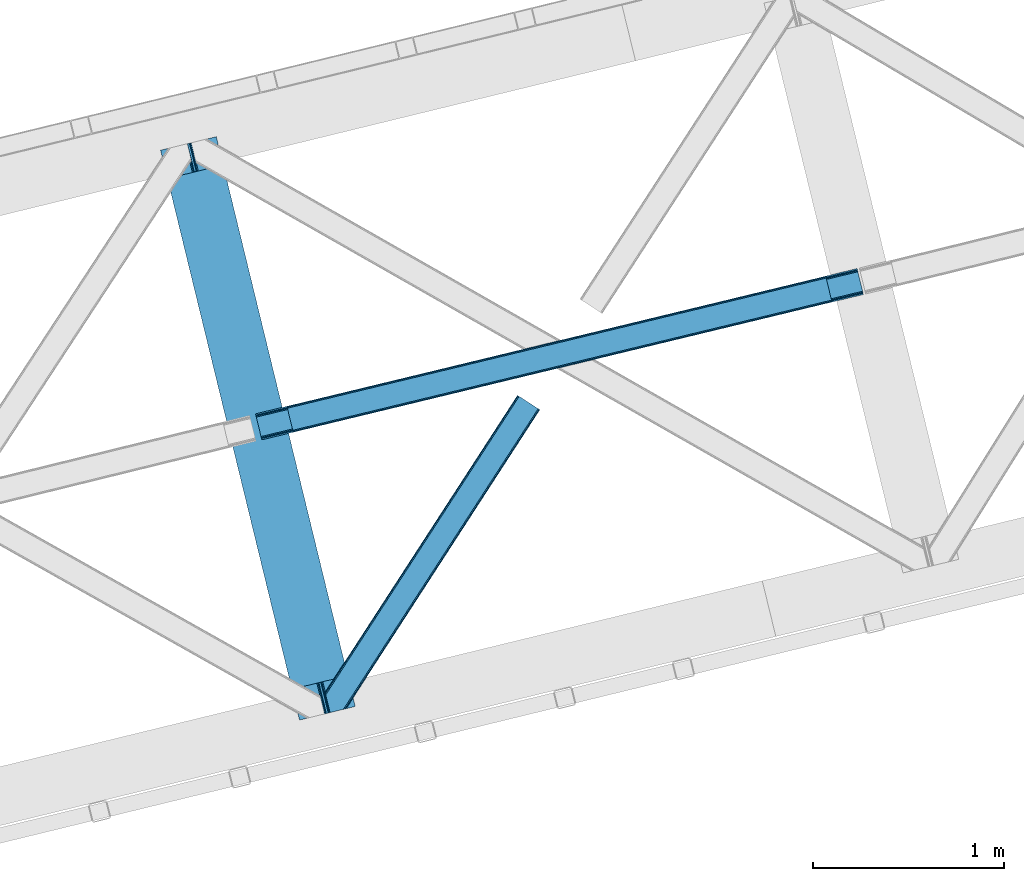
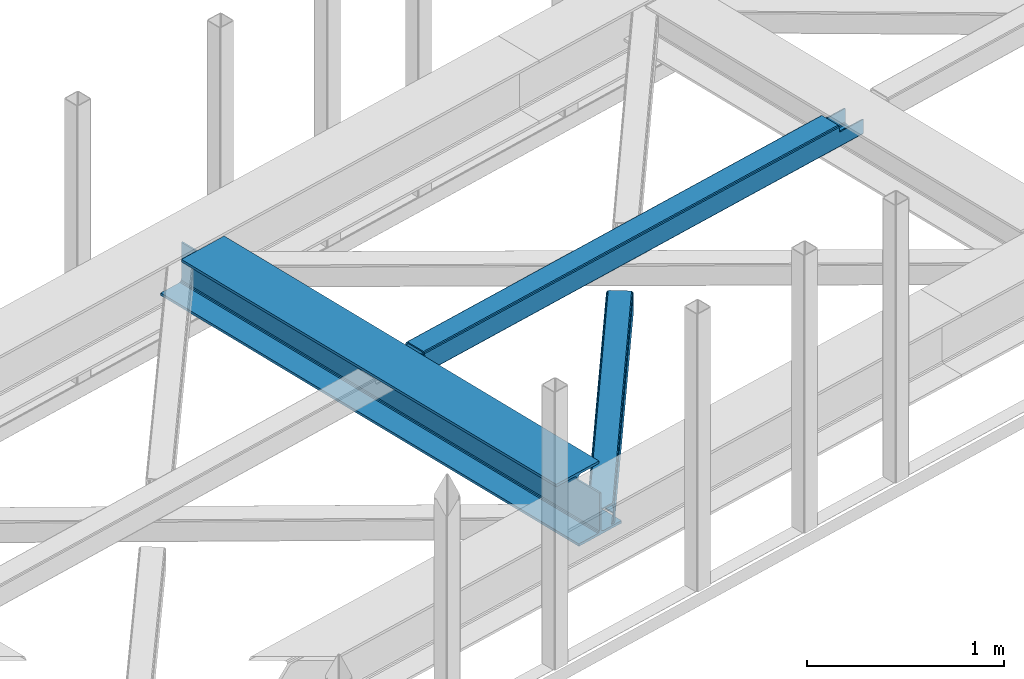
# One storey, part 36 of 66: 2 beams, 1 member.
"""IFC4 building model written with IfcOpenShell, lengths in millimetres."""

from ifc_helpers import new_model, entity, si_unit, converted_unit, derived_unit, direction, frame, origin, place, context, subcontext, project, spatial, triangles, polygons, material, type_object, element, save


model = new_model("IFC4")

# Units and contexts
model_context = context("Model", 3, precision=0.01, world=origin(), true_north=direction((6.12303176911189e-17, 1.0)))
plan_context = context("Plan", 3, precision=0.01, world=origin(), true_north=direction((6.12303176911189e-17, 1.0)))
body_context = subcontext(model_context, "Body", "Model", "MODEL_VIEW")
ifc_project = project(units=[si_unit("LENGTHUNIT", "METRE", prefix="MILLI"), si_unit("AREAUNIT", "SQUARE_METRE"), si_unit("VOLUMEUNIT", "CUBIC_METRE"), converted_unit("PLANEANGLEUNIT", "DEGREE", entity("IfcRatioMeasure", 0.0174532925199433), si_unit("PLANEANGLEUNIT", "RADIAN"), dimensions=[0, 0, 0, 0, 0, 0, 0]), si_unit("MASSUNIT", "GRAM", prefix="KILO"), derived_unit("MASSDENSITYUNIT", [(si_unit("MASSUNIT", "GRAM", prefix="KILO"), 1), (si_unit("LENGTHUNIT", "METRE"), -3)]), derived_unit("MOMENTOFINERTIAUNIT", [(si_unit("LENGTHUNIT", "METRE"), 4)]), si_unit("TIMEUNIT", "SECOND"), si_unit("FREQUENCYUNIT", "HERTZ"), si_unit("THERMODYNAMICTEMPERATUREUNIT", "DEGREE_CELSIUS"), derived_unit("THERMALTRANSMITTANCEUNIT", [(si_unit("MASSUNIT", "GRAM", prefix="KILO"), 1), (si_unit("THERMODYNAMICTEMPERATUREUNIT", "KELVIN"), -1), (si_unit("TIMEUNIT", "SECOND"), -3)]), derived_unit("VOLUMETRICFLOWRATEUNIT", [(si_unit("LENGTHUNIT", "METRE"), 3), (si_unit("TIMEUNIT", "SECOND"), -1)]), derived_unit("MASSFLOWRATEUNIT", [(si_unit("MASSUNIT", "GRAM", prefix="KILO"), 1), (si_unit("TIMEUNIT", "SECOND"), -1)]), derived_unit("ROTATIONALFREQUENCYUNIT", [(si_unit("TIMEUNIT", "SECOND"), -1)]), si_unit("ELECTRICCURRENTUNIT", "AMPERE"), si_unit("ELECTRICVOLTAGEUNIT", "VOLT"), si_unit("POWERUNIT", "WATT"), si_unit("FORCEUNIT", "NEWTON", prefix="KILO"), si_unit("ILLUMINANCEUNIT", "LUX"), si_unit("LUMINOUSFLUXUNIT", "LUMEN"), si_unit("LUMINOUSINTENSITYUNIT", "CANDELA"), derived_unit("USERDEFINED", [(si_unit("MASSUNIT", "GRAM", prefix="KILO"), -1), (si_unit("LENGTHUNIT", "METRE"), -2), (si_unit("TIMEUNIT", "SECOND"), 3), (si_unit("LUMINOUSFLUXUNIT", "LUMEN"), 1)]), derived_unit("LINEARVELOCITYUNIT", [(si_unit("LENGTHUNIT", "METRE"), 1), (si_unit("TIMEUNIT", "SECOND"), -1)]), si_unit("PRESSUREUNIT", "PASCAL"), derived_unit("USERDEFINED", [(si_unit("LENGTHUNIT", "METRE"), -2), (si_unit("MASSUNIT", "GRAM", prefix="KILO"), 1), (si_unit("TIMEUNIT", "SECOND"), -2)]), derived_unit("LINEARFORCEUNIT", [(si_unit("MASSUNIT", "GRAM", prefix="KILO"), 1), (si_unit("LENGTHUNIT", "METRE"), 1), (si_unit("TIMEUNIT", "SECOND"), -2), (si_unit("LENGTHUNIT", "METRE"), -1)]), derived_unit("PLANARFORCEUNIT", [(si_unit("MASSUNIT", "GRAM", prefix="KILO"), 1), (si_unit("LENGTHUNIT", "METRE"), 1), (si_unit("TIMEUNIT", "SECOND"), -2), (si_unit("LENGTHUNIT", "METRE"), -2)])], contexts=[model_context, plan_context])

# Site, building, storey
site_placement = place(None, origin())
site = spatial("IfcSite", under=ifc_project, at=site_placement, CompositionType="ELEMENT")
building_placement = place(site_placement, origin())
building = spatial("IfcBuilding", under=site, at=building_placement, CompositionType="ELEMENT")
storey_placement = place(building_placement, frame((0.0, 0.0, 19800.0)))
storey = spatial("IfcBuildingStorey", under=building, at=storey_placement, Name="06", CompositionType="ELEMENT", Elevation=19800.0)

# Beams
ifc_material = material(Name="Metal painted (White)")
beam_type = type_object("IfcBeamType", PredefinedType="BEAM")
beam_1_placement = place(storey_placement, frame((-33462.57, 9638.07, 3807.02)))
element("IfcBeam", 1, at=beam_1_placement, inside=storey, type_object=beam_type, material=ifc_material, ObjectType="Steel Beam", PredefinedType="BEAM", context=body_context, shape_type="Tessellation", body=[
    polygons([(1018.16648378329, 71.0478278971032, 15.5000000000008), (1018.16648378329, 71.0478278971032, 0.0), (291.465617442446, 3052.25531830422, 0.0), (291.465617442446, 3052.25531830421, 15.5000000000008), (894.779372399325, 40.970914087328, 15.5000000000008), (168.078506058474, 3022.17840449444, 15.5000000000008), (888.087028625375, 39.3395844888254, 16.8701684147984), (161.386162284524, 3020.54707489594, 16.8701684147984), (882.413533524755, 37.956610033653, 20.7720779386434), (155.7126671839, 3019.16410044076, 20.7720779386434), (878.62262529618, 37.0325360459173, 26.6116982174294), (151.921758955325, 3018.24002645303, 26.6116982174294), (877.291435352783, 36.708044413504, 33.500000000001), (150.590569011937, 3017.91553482062, 33.500000000001), (140.875048430518, 3015.54727389071, 33.500000000001), (140.875048430514, 3015.54727389071, 259.000000000002), (150.590569011932, 3017.91553482062, 259.000000000002), (-4.33146851719357e-12, 2981.20749040711, 0.0), (4.33146851719357e-12, 2981.20749040711, 15.4999999999965), (123.387111383968, 3011.28440421689, 15.5000000000008), (130.079455157926, 3012.91573381539, 16.8701684147984), (135.752950258542, 3014.29870827056, 20.7720779386391), (139.543858487122, 3015.2227822583, 26.6116982174294), (877.291435352779, 36.7080444135062, 259.000000000002), (867.575914771365, 34.3397834836025, 259.000000000002), (867.575914771365, 34.3397834836003, 33.500000000001), (866.244724827968, 34.0152918511859, 26.6116982174294), (862.453816599389, 33.0912178634513, 20.7720779386391), (856.780321498773, 31.7082434082789, 16.8701684147984), (850.087977724815, 30.0769138097752, 15.5000000000008), (726.700866340851, 2.16573425859679e-12, 15.4999999999965), (726.700866340851, 2.16573425859679e-12, 0.0), (838.124523615916, 197.385937999181, 259.069791973884), (186.469722099967, 2870.72539801218, 259.000000000002), (186.69311520182, 2869.80895360721, 259.617303331124), (186.705504045446, 2869.75812937344, 266.500003008253), (837.979344808143, 197.981416001706, 266.500002998871), (837.979694928895, 197.979979696973, 260.000004007589), (828.499586345872, 194.645865944432, 259.006343171919), (828.276216326111, 195.562317481914, 259.617303331124), (828.263827482481, 195.613141715685, 266.500003008253), (176.989986719788, 2867.38985508742, 266.500002998871), (176.989636599032, 2867.39129139215, 260.000004007589), (176.844830940692, 2867.98534020594, 259.07612046749), (176.754201518548, 2868.35713708228, 259.000000000002), (839.31083267807, 198.304685446393, 273.388305639783), (843.101109266766, 199.231350618306, 279.227924098781), (848.774180214305, 200.616065081981, 283.129832400619), (855.466371895425, 202.248018612794, 284.500000377228), (978.853400583278, 232.325271667905, 284.500000138971), (978.851730776613, 232.332121736637, 299.999995328161), (687.386308679347, 161.283492472594, 299.999995890962), (687.387978486003, 161.276642403863, 284.500000701776), (810.775007173847, 191.353895458974, 284.500000463519), (817.467494069986, 192.984637925555, 283.129832461069), (823.141405718746, 194.365903570076, 279.227924137322), (826.932940505738, 195.287407219375, 273.388305663684), (175.658498849857, 2867.06658564273, 273.388305639783), (171.868222261161, 2866.13992047082, 279.227924098781), (166.195151313627, 2864.75520600715, 283.129832400619), (159.502959632502, 2863.12325247633, 284.500000377228), (36.1159309446533, 2833.04599942122, 284.500000138971), (36.1176007513094, 2833.03914935249, 299.999995328161), (327.58302284858, 2904.08777861653, 299.999995890962), (327.581353041928, 2904.09462868526, 284.500000701776), (204.19432435408, 2874.01737563015, 284.500000463519), (197.501837457945, 2872.38663316357, 283.129832461069), (191.827925809185, 2871.00536751905, 279.227924137322), (188.036391022189, 2870.08386386975, 273.388305663684)], [[[1, 2, 3, 4]], [[5, 1, 4, 6]], [[7, 5, 6, 8]], [[9, 7, 8, 10]], [[11, 9, 10, 12]], [[13, 11, 12, 14]], [[15, 16, 17, 14, 12, 10, 8, 6, 4, 3, 18, 19, 20, 21, 22, 23]], [[13, 24, 25, 26, 27, 28, 29, 30, 31, 32, 2, 1, 5, 7, 9, 11]], [[2, 32, 18, 3]], [[32, 31, 19, 18]], [[31, 30, 20, 19]], [[27, 26, 15, 23]], [[28, 27, 23, 22]], [[29, 28, 22, 21]], [[30, 29, 21, 20]], [[33, 24, 13, 14, 17, 34, 35, 36, 37, 38]], [[25, 39, 40, 41, 42, 43, 44, 16, 15, 26]], [[39, 25, 24, 33]], [[45, 34, 17, 16]], [[41, 40, 38, 37, 46, 47, 48, 49, 50, 51, 52, 53, 54, 55, 56, 57]], [[42, 58, 59, 60, 61, 62, 63, 64, 65, 66, 67, 68, 69, 36, 35, 43]], [[46, 37, 36, 69]], [[47, 46, 69, 68]], [[48, 47, 68, 67]], [[49, 48, 67, 66]], [[50, 49, 66, 65]], [[51, 50, 65, 64]], [[52, 51, 64, 63]], [[53, 52, 63, 62]], [[54, 53, 62, 61]], [[55, 54, 61, 60]], [[56, 55, 60, 59]], [[57, 56, 59, 58]], [[41, 57, 58, 42]]], closed=False),
])
beam_2_placement = place(storey_placement, frame((-32965.83, 11104.16, 3967.02)))
element("IfcBeam", 2, at=beam_2_placement, inside=storey, type_object=beam_type, material=ifc_material, ObjectType="Steel Beam", PredefinedType="BEAM", context=body_context, shape_type="Tessellation", body=[
    polygons([(195.773362086805, 46.4834740443067, 115.55102592408), (195.457883430396, 47.7776892807251, 122.247985460716), (3014.38527381378, 728.721626181414, 123.12224722229), (3014.70075247017, 727.427410945045, 116.425287685654), (194.559476226856, 51.4633024520939, 127.925391947854), (3013.48686661024, 732.407239352741, 128.799653709428), (193.214914828827, 56.9792123632816, 131.718911713636), (3012.14230521221, 737.923149263937, 132.59317347521), (191.628896520703, 63.485671732071, 133.051015762066), (3010.55628690406, 744.429608632842, 133.925277523644), (170.077675576957, 151.897099708507, 133.050958784443), (2989.00506596032, 832.84103660928, 133.925220546017), (168.491657268782, 158.403559077509, 131.718846349701), (2987.41904765216, 839.347495978191, 132.593108111284), (167.147095870749, 163.919468988697, 127.925319474355), (2986.07448625413, 844.863405889383, 128.799581235929), (166.248688667217, 167.605082160037, 122.247908236757), (2985.17607905059, 848.549019060736, 123.122169998335), (165.933210010851, 168.8992973963, 115.550947031982), (2984.86060039422, 849.843234297047, 116.425208793556), (2983.20281416778, 856.644113372169, 101.478006524657), (2983.20281416778, 856.644113372165, 123.425204728752), (2983.51829282418, 855.349898135762, 130.122165933532), (2984.41670002772, 851.664284964408, 135.79957717113), (2985.76126142575, 846.148375053212, 139.59310404648), (2987.34727973389, 839.641915684392, 140.925216481214), (3012.21407313051, 737.628729557732, 140.925282224628), (3013.8000914387, 731.122270188704, 139.59317817619), (3015.14465283673, 725.606360277508, 135.799658410417), (3016.04306004026, 721.920747106161, 130.122251923274), (3016.35853869166, 720.626531890475, 123.425292386639), (3016.35853869662, 720.626531869957, 101.478006524657), (3014.70075247017, 727.427410945067, 101.478006524657), (2984.86060039423, 849.84323429706, 101.478006524657), (165.933210010851, 168.899297396285, 100.498230416086), (195.773362086805, 46.4834740442915, 100.498230416086), (197.431148312824, 39.6825949709209, 100.498230416086), (197.43114831324, 39.6825949691927, 122.551030625065), (197.115669656861, 40.9768102055115, 129.247990161705), (196.217262453329, 44.6624233768565, 134.925396648843), (194.872701055296, 50.1783332880529, 138.718916414629), (193.286682747138, 56.6847926569592, 140.05102046305), (168.419889350514, 158.697978783619, 140.05095471964), (166.833871042356, 165.204438152528, 138.718842284902), (165.489309644327, 170.72034806372, 134.925315409556), (164.590902440796, 174.40596123506, 129.247904171949), (164.275423784408, 175.700176471401, 122.550942967179), (164.275423784408, 175.700176471396, 100.498230416086), (3178.97617625457, 767.110005888593, 100.478006524658), (3178.97617625457, 767.110005888593, 25.476231908301), (31.4979383023929, 6.8008791007736, 24.5000734310727), (31.4979383023973, 6.80087910076277, 99.4982304160815), (194.801318159086, 46.2486657901886, 99.4982304160858), (1.657786226439, 129.21670245276, 24.4999945389742), (3149.13602417862, 889.525829240584, 25.4761530162069), (3149.13602417862, 889.525829240586, 100.478006524658), (2985.83264432192, 850.078042551158, 100.478006524658), (1.65778622644333, 129.216702452756, 99.4982304160815), (3180.63396247261, 760.309126848315, 18.4762359731086), (3180.63396244516, 760.309126959369, 100.478006524658), (3017.33058261229, 720.861340173872, 100.478006524658), (33.1557245287323, 2.60754404735053e-08, 99.4982304160815), (33.1557245329728, 8.55031885294011e-09, 17.5000774958759), (3147.47823795218, 896.326708315696, 100.478006524658), (3147.47823795218, 896.326708315694, 18.4761483152224), (0.0, 136.017581527866, 17.4999898379897), (0.0, 136.017581527868, 99.4982304160815), (163.303379856698, 175.465368217291, 99.4982304160858), (3015.67279639788, 727.662219199167, 100.478006524658), (2984.17485809549, 856.878921626272, 100.478006524658), (3149.451502835, 888.231614004263, 18.7791934795625), (3150.34991003854, 884.546000832907, 13.1017869924287), (3151.69447143658, 879.030090921715, 9.30826722664713), (3153.28048974473, 872.523631552807, 7.97616317822152), (3174.83171068847, 784.112203576368, 7.97622015583976), (3176.41772899663, 777.605744207462, 9.30833259058183), (3177.76229039466, 772.08983429627, 13.1018594659232), (3178.66069759819, 768.404221124921, 18.7792707035258), (3180.31848382461, 761.603342049926, 11.779274768316), (3179.42007662107, 765.288955221284, 6.10186353071347), (3178.07551522304, 770.804865132474, 2.30833665536775), (3176.48949691491, 777.311324501259, 0.976224220647339), (3151.62270351829, 879.324510627918, 0.976158477228353), (3150.03668521011, 885.830969996914, 2.30826252564963), (3148.69212381207, 891.346879908106, 6.10178229143121), (3147.79371660855, 895.032493079451, 11.7791887785693), (196.459104385525, 39.4477867150768, 99.4982304160858), (164.961166083132, 168.664489142182, 99.4982304160858), (27.3534727362954, 23.803076788538, 7.0000616786114), (28.939491044419, 17.2966174197507, 8.33217411333182), (30.2840524424519, 11.7807075085608, 12.1257009886819), (31.1824596459836, 8.0950943372072, 17.8031122262801), (1.97326488280931, 127.922487216496, 17.8030350023211), (2.87167208633673, 124.236874045166, 12.125628515183), (4.21623348436958, 118.720964133976, 8.33210874940145), (5.80225179254949, 112.214504764981, 7.00000470098017), (0.315478656383311, 134.723366291536, 10.8030303013496), (1.21388585991939, 131.037753120189, 5.12562381421585), (2.55844725794791, 125.521843208997, 1.33210404842994), (4.14446556610183, 119.015383840088, 4.33146851719357e-12), (29.0112589627301, 17.0021977134283, 6.5743414654662e-05), (30.597277270884, 10.4957383445198, 1.33217817815239), (31.9418386689169, 4.97982843332773, 5.12570505349811), (32.8402458724486, 1.29421526199143, 10.8031162910963)], [[[1, 2, 3, 4]], [[2, 5, 6, 3]], [[5, 7, 8, 6]], [[7, 9, 10, 8]], [[11, 12, 10, 9]], [[11, 13, 14, 12]], [[13, 15, 16, 14]], [[15, 17, 18, 16]], [[17, 19, 20, 18]], [[21, 22, 23, 24, 25, 26, 27, 28, 29, 30, 31, 32, 33, 4, 3, 6, 8, 10, 12, 14, 16, 18, 20, 34]], [[35, 19, 17, 15, 13, 11, 9, 7, 5, 2, 1, 36, 37, 38, 39, 40, 41, 42, 43, 44, 45, 46, 47, 48]], [[42, 41, 28, 27]], [[41, 40, 29, 28]], [[40, 39, 30, 29]], [[39, 38, 31, 30]], [[27, 26, 43, 42]], [[47, 46, 23, 22]], [[46, 45, 24, 23]], [[45, 44, 25, 24]], [[44, 43, 26, 25]], [[33, 49, 50, 51, 52, 53, 1, 4]], [[54, 55, 56, 57, 20, 19, 35, 58]], [[59, 60, 61, 31, 38, 37, 62, 63]], [[64, 65, 66, 67, 68, 47, 22, 21]], [[61, 60, 49, 69]], [[64, 70, 57, 56]], [[65, 64, 56, 55, 71, 72, 73, 74, 75, 76, 77, 78, 50, 49, 60, 59, 79, 80, 81, 82, 83, 84, 85, 86]], [[87, 53, 52, 62]], [[67, 58, 88, 68]], [[89, 90, 76, 75]], [[90, 91, 77, 76]], [[91, 92, 78, 77]], [[92, 51, 50, 78]], [[54, 93, 71, 55]], [[93, 94, 72, 71]], [[94, 95, 73, 72]], [[95, 96, 74, 73]], [[89, 75, 74, 96]], [[66, 97, 98, 99, 100, 101, 102, 103, 104, 63, 62, 52, 51, 92, 91, 90, 89, 96, 95, 94, 93, 54, 58, 67]], [[63, 104, 79, 59]], [[104, 103, 80, 79]], [[103, 102, 81, 80]], [[102, 101, 82, 81]], [[100, 99, 84, 83]], [[99, 98, 85, 84]], [[98, 97, 86, 85]], [[97, 66, 65, 86]], [[83, 82, 101, 100]]], closed=False),
])

# Member
member_type = type_object("IfcMemberType", PredefinedType="BRACE")
member_placement = place(storey_placement, frame((-32601.72, 9677.15, 3823.06)))
element("IfcMember", 3, at=member_placement, inside=storey, type_object=member_type, ObjectType="Steel Horizontal Brace", PredefinedType="BRACE", context=body_context, shape_type="Tessellation", body=[
    triangles([(1021.07255859375, 1650.67133789062, 0.386022949220205), (1109.18811035156, 1593.56668395996, 0.386022949220205), (114.153497314452, 251.255593872071, 0.0209289550803078), (148.353735351564, 110.958343505859, 0.0), (1007.50594482422, 1659.46266174316, 11.1900146484368), (0.523223876953125, 105.142419433594, 10.8528259277336), (0.0, 107.29112548828, 17.4803283691399), (108.346874999999, 270.855560302734, 9.46221313476781), (0.634844970703853, 104.692446899413, 9.46221313476781), (1010.68947143555, 1657.39999694824, 5.51361694336083), (110.123510742189, 267.789468383789, 5.14852294922093), (109.277050781249, 271.259024047851, 8.46227416992406), (108.646856689455, 271.243908691406, 9.38547363281396), (1015.454296875, 1654.31297607422, 1.71849975586156), (111.972235107423, 260.203884887695, 1.3557312011726), (1006.38740844727, 1660.18587341309, 17.8872802734368), (1006.37345581055, 1660.16610717773, 122.887847900391), (0.0, 107.29112548828, 122.480895996094), (1021.05860595703, 1650.64575805664, 140.386779785156), (1015.43801879883, 1654.28855895996, 139.054302978515), (3.51838989257885, 92.8559600830067, 138.647351074218), (5.69965209961083, 83.9088317871083, 139.977502441408), (1010.67319335938, 1657.37674255371, 135.26151123047), (1.66966552734448, 100.442706298827, 134.854559326173), (1007.4919921875, 1659.44057006836, 129.58278808594), (0.434857177733647, 105.511001586914, 129.178161621094), (112.781488037108, 252.660159301757, 9.46221313476781), (5.05317993164135, 86.5644836425781, 9.46221313476781), (1021.32603149414, 1650.50506896973, 8.71807250976781), (113.111700439455, 252.928747558593, 9.38547363281396), (113.818634033203, 251.768353271484, 8.76923217773583), (1016.56353149414, 1653.59208984375, 12.5131896972671), (3.95092163085792, 91.089788818359, 12.1039123535156), (1026.9489440918, 1646.86343078613, 7.3879211425774), (114.255816650391, 250.833526611328, 8.40646362304688), (116.434753417969, 241.902676391601, 7.02050170898656), (1013.38000488281, 1655.65475463867, 18.189587402343), (2.71378784179615, 96.1580841064442, 17.7826354980461), (1012.25914306641, 1656.37680358887, 24.886853027343), (2.28125610351708, 97.9382080078121, 24.4799011230461), (1103.31172485352, 1597.372265625, 7.3879211425774), (146.072479248047, 120.311260986327, 7.00189819336083), (150.534997558592, 102.010052490234, 1.33015136718677), (148.353735351564, 110.953692626952, 8.46227416992406), (152.383721923827, 94.4244689941406, 5.1229431152351), (153.234832763672, 90.9316589355458, 8.46227416992406), (1012.24984130859, 1656.36052551269, 115.885949707033), (2.28125610351708, 97.9382080078121, 115.478997802737), (1013.36837768555, 1655.63498840332, 122.583215332033), (2.71378784179615, 96.1580841064442, 122.176263427737), (1016.54957885742, 1653.57116088867, 128.261938476564), (3.95092163085792, 91.089788818359, 127.852661132813), (1021.31207885742, 1650.48297729492, 132.054730224609), (5.79964599609229, 83.5030426025387, 131.645452880861), (1026.93266601563, 1646.8401763916, 133.38720703125), (7.98090820312427, 74.554751586913, 132.975604248048), (26.1542175292961, 0.0, 139.963549804688), (26.1542175292961, 0.0, 132.963977050782), (1109.17183227539, 1593.54110412598, 140.386779785156), (85.8808044433608, 14.5589950561516, 139.975177001954), (1103.30009765625, 1597.3501739502, 133.38720703125), (75.9744323730483, 12.1440261840817, 132.973278808593), (1123.85930786133, 1584.02656860351, 122.887847900391), (1122.74077148438, 1584.75094299316, 129.58278808594), (110.646734619142, 20.5958358764638, 122.478570556643), (108.760803222656, 20.1359802246097, 129.175836181643), (1119.55724487305, 1586.81244506836, 135.26151123047), (103.391363525392, 18.8279205322269, 134.852233886719), (1114.79241943359, 1589.89946594238, 139.054302978515), (95.3569702148452, 16.8693191528309, 138.645025634767), (1123.87093505859, 1584.04633483887, 17.8872802734368), (110.646734619142, 20.5958358764638, 17.478002929689), (1122.75472412109, 1584.77187194824, 11.1900146484368), (1113.69713745117, 1590.64244384766, 12.5131896972671), (1116.8806640625, 1588.57861633301, 18.189587402343), (1117.996875, 1587.85191650391, 24.886853027343), (1119.57119750977, 1586.83686218262, 5.51361694336083), (1114.80869750976, 1589.92504577637, 1.71849975586156), (1108.93231201172, 1593.73062744141, 8.71807250976781), (1113.68318481445, 1590.62035217285, 128.261938476564), (1117.98524780274, 1587.83563842773, 115.885949707033), (1116.86903686524, 1588.55885009766, 122.583215332033), (1108.918359375, 1593.70737304687, 132.054730224609), (85.4505981445327, 14.454350280761, 131.643127441406), (93.4849914550796, 16.4129516601552, 127.850335693362), (98.8521057128892, 17.721011352538, 122.173937988282), (100.74036254883, 18.1808670043938, 115.476672363282), (100.74036254883, 18.1808670043938, 24.4775756835952), (93.4849914550796, 16.4129516601552, 12.1015869140647), (107.895739746094, 19.9255279541012, 9.46221313476781), (98.8521057128892, 17.721011352538, 17.7803100585952), (88.6992370605476, 15.2461624145508, 9.46221313476781), (108.372454833985, 20.0412185668938, 10.8481750488281), (152.669750976562, 89.0306121826161, 9.46221313476781), (153.097631835939, 90.4723846435536, 8.7041198730476), (148.239788818359, 107.195782470702, 9.46221313476781), (148.563024902345, 109.771206665038, 8.84597167968968), (148.458380126955, 108.917770385742, 9.05061035156177), (148.349084472655, 108.050381469726, 9.25757446289208)], [[1, 2, 3], [4, 3, 2], [5, 6, 7], [8, 6, 5], [8, 9, 6], [10, 11, 12], [12, 5, 10], [12, 13, 5], [10, 14, 11], [15, 11, 14], [14, 1, 15], [3, 15, 1], [7, 16, 5], [17, 16, 18], [7, 18, 16], [19, 20, 21], [21, 22, 19], [20, 23, 24], [24, 21, 20], [23, 25, 26], [26, 24, 23], [25, 17, 18], [18, 26, 25], [8, 27, 9], [28, 9, 27], [29, 30, 31], [32, 33, 27], [27, 29, 32], [33, 28, 27], [34, 29, 35], [35, 36, 34], [32, 37, 38], [38, 33, 32], [37, 39, 40], [40, 38, 37], [41, 34, 36], [36, 42, 41], [36, 3, 42], [15, 35, 11], [35, 15, 3], [11, 35, 12], [3, 36, 35], [42, 3, 4], [43, 44, 4], [44, 43, 45], [4, 44, 42], [45, 46, 44], [39, 47, 48], [48, 40, 39], [47, 49, 48], [50, 48, 49], [49, 51, 50], [52, 50, 51], [51, 53, 52], [54, 52, 53], [53, 55, 54], [56, 54, 55], [52, 24, 50], [54, 56, 22], [56, 57, 22], [56, 58, 57], [21, 54, 22], [52, 21, 24], [33, 9, 28], [52, 54, 21], [7, 40, 48], [48, 50, 18], [18, 7, 48], [24, 26, 50], [50, 26, 18], [7, 38, 40], [38, 9, 33], [9, 38, 6], [7, 6, 38], [59, 22, 60], [59, 19, 22], [22, 57, 60], [61, 56, 55], [56, 61, 62], [58, 56, 62], [63, 64, 65], [66, 65, 64], [64, 67, 66], [68, 66, 67], [67, 69, 68], [70, 68, 69], [69, 59, 70], [60, 70, 59], [71, 63, 65], [65, 72, 71], [73, 74, 75], [76, 63, 71], [73, 75, 71], [73, 77, 74], [75, 76, 71], [74, 77, 78], [41, 2, 1], [2, 79, 78], [79, 2, 41], [79, 74, 78], [64, 80, 67], [81, 63, 76], [63, 82, 64], [82, 63, 81], [64, 82, 80], [59, 61, 19], [69, 67, 80], [80, 83, 69], [83, 61, 59], [59, 69, 83], [32, 14, 10], [1, 34, 41], [1, 29, 34], [29, 1, 14], [32, 29, 14], [39, 16, 17], [5, 37, 32], [10, 5, 32], [37, 5, 16], [39, 37, 16], [20, 51, 23], [19, 61, 55], [55, 53, 19], [53, 51, 20], [20, 19, 53], [25, 23, 51], [17, 47, 39], [49, 17, 25], [17, 49, 47], [49, 25, 51], [61, 83, 84], [84, 62, 61], [83, 80, 85], [85, 84, 83], [80, 82, 86], [86, 85, 80], [82, 81, 87], [87, 86, 82], [81, 76, 87], [88, 87, 76], [86, 65, 66], [84, 70, 60], [62, 57, 58], [60, 62, 84], [62, 60, 57], [85, 70, 84], [85, 86, 68], [68, 70, 85], [66, 68, 86], [72, 65, 87], [89, 90, 91], [86, 87, 65], [89, 92, 90], [88, 91, 72], [88, 72, 87], [93, 72, 91], [91, 90, 93], [73, 71, 72], [77, 94, 95], [46, 45, 77], [73, 93, 94], [94, 77, 73], [93, 90, 94], [2, 78, 4], [43, 4, 78], [78, 77, 43], [45, 43, 77], [72, 93, 73], [79, 41, 42], [89, 74, 96], [74, 79, 44], [44, 97, 74], [74, 98, 99], [98, 74, 97], [99, 96, 74], [96, 92, 89], [42, 44, 79], [76, 75, 88], [91, 88, 75], [75, 74, 91], [89, 91, 74], [96, 99, 94], [99, 98, 95], [98, 97, 95], [97, 44, 46], [96, 94, 90], [90, 92, 96]]),
])

save(model, "model.ifc")
